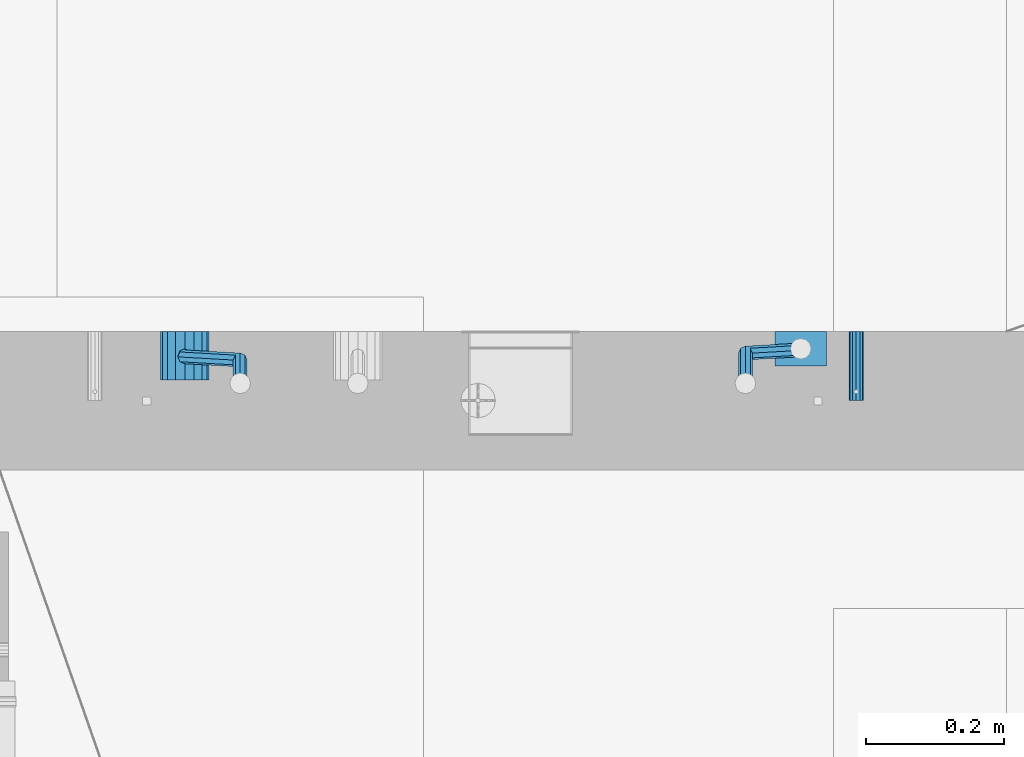
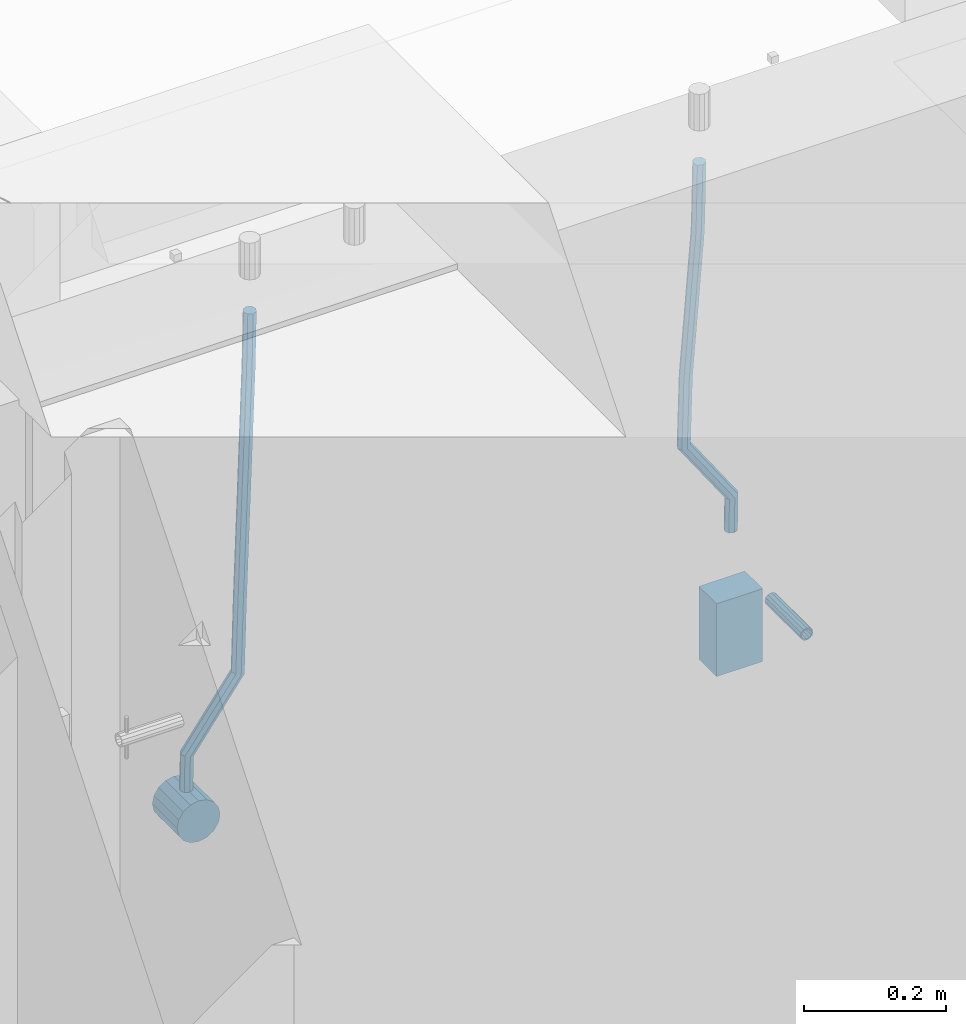
# One storey, part 157 of 334: 5 beams, 2 elements without a shape of their own.
"""IFC2X3 building model written with IfcOpenShell, lengths in millimetres."""

import ifcopenshell
import ifcopenshell.guid

model = None  # the IFC model being written
_history = None  # IfcOwnerHistory: only IFC2X3 demands one
_inside = {}  # id of a spatial element -> (the spatial element, [elements in it])
_under = {}  # id of a project, library or spatial element -> (it, [spatial elements below it])
_declared = {}  # id of a project -> (the project, [libraries it declares])
_typed = {}  # id of a type object -> (the type object, [elements of that type])
_made_of = {}  # id of a material, layer set ... -> (it, [elements and type objects made of it])


def new_model(schema):
    """Start an empty IFC model of exactly this schema.

    Asked for "IFC4X3", IfcOpenShell would pick the latest addendum, in which some entities
    have other attributes; the version numbers below select the first issue.
    IFC2X3 requires an IfcOwnerHistory on every rooted entity: one is made here for all.
    """
    global model, _history
    if schema == "IFC4X3":
        model = ifcopenshell.file(schema_version=(4, 3, 0, 0))
    else:
        model = ifcopenshell.file(schema=schema)
    _inside.clear()
    _under.clear()
    _declared.clear()
    _typed.clear()
    _made_of.clear()
    _history = None
    if model.schema == "IFC2X3":
        org = make("IfcOrganization", Name="unknown")
        user = make(
            "IfcPersonAndOrganization",
            ThePerson=make("IfcPerson", FamilyName="unknown"),
            TheOrganization=org,
        )
        app = make(
            "IfcApplication",
            ApplicationDeveloper=org,
            Version="unknown",
            ApplicationFullName="unknown",
            ApplicationIdentifier="unknown",
        )
        _history = make(
            "IfcOwnerHistory",
            OwningUser=user,
            OwningApplication=app,
            ChangeAction="ADDED",
            CreationDate=0,
        )
    return model


def make(cls, **values):
    """One entity of the class cls with the attributes given. An attribute that is None is left unset."""
    return model.create_entity(
        cls, **{name: value for name, value in values.items() if value is not None}
    )


def rooted(cls, **values):
    """An entity with a GlobalId (a new one), such as an element, a storey or a relation."""
    return make(cls, GlobalId=ifcopenshell.guid.new(), OwnerHistory=_history, **values)


def si_unit(unit_type, name, prefix=None):
    """IfcSIUnit, for example si_unit("LENGTHUNIT", "METRE", prefix="MILLI")."""
    return make("IfcSIUnit", UnitType=unit_type, Prefix=prefix, Name=name)


def assignment(units):
    """IfcUnitAssignment: the units of a project."""
    return None if units is None else make("IfcUnitAssignment", Units=units)


def point(xyz):
    """IfcCartesianPoint."""
    return None if xyz is None else make("IfcCartesianPoint", Coordinates=xyz)


def direction(xyz):
    """IfcDirection."""
    return None if xyz is None else make("IfcDirection", DirectionRatios=xyz)


def frame(location, z_axis=None, x_axis=None):
    """IfcAxis2Placement3D, a coordinate frame: its origin and axes. An axis left out is left unset."""
    return make(
        "IfcAxis2Placement3D",
        Location=point(location),
        Axis=direction(z_axis),
        RefDirection=direction(x_axis),
    )


def origin_with_axes():
    """The frame at (0, 0, 0) with the z axis (0, 0, 1) and the x axis (1, 0, 0) written out."""
    return frame((0.0, 0.0, 0.0), z_axis=(0.0, 0.0, 1.0), x_axis=(1.0, 0.0, 0.0))


def place(relative_to, where):
    """IfcLocalPlacement: puts the frame where relative to a parent placement (None: the world)."""
    return make(
        "IfcLocalPlacement", PlacementRelTo=relative_to, RelativePlacement=where
    )


def context(
    kind, dimensions, precision=None, world=None, true_north=None, identifier=None
):
    """IfcGeometricRepresentationContext, for example the 3D "Model" context."""
    return make(
        "IfcGeometricRepresentationContext",
        ContextIdentifier=identifier,
        ContextType=kind,
        CoordinateSpaceDimension=dimensions,
        Precision=precision,
        WorldCoordinateSystem=world,
        TrueNorth=true_north,
    )


def subcontext(parent, identifier, kind, view, scale=None):
    """IfcGeometricRepresentationSubContext, for example "Body" below "Model"."""
    return make(
        "IfcGeometricRepresentationSubContext",
        ContextIdentifier=identifier,
        ContextType=kind,
        ParentContext=parent,
        TargetScale=scale,
        TargetView=view,
    )


def project(units=None, contexts=None):
    """IfcProject with its units and contexts."""
    return rooted(
        "IfcProject",
        Name="project",
        RepresentationContexts=contexts,
        UnitsInContext=assignment(units),
    )


def spatial(cls, under=None, at=None, **own):
    """A site, building, storey or space (cls), placed at a placement, below another one or the project."""
    s = rooted(cls, ObjectPlacement=at, **own)
    if under is not None:
        _under.setdefault(under.id(), (under, []))[1].append(s)
    return s


def faces_of(points, faces, orient=None, outer=None):
    """IfcFace entities. A face is a list of loops; a loop is a list of indices into points, from 0.

    orient and outer hold one flag for each loop. By default every Orientation is true, the
    first loop of a face is its IfcFaceOuterBound and the others are IfcFaceBound.
    """
    made = []
    for i, loops in enumerate(faces):
        bounds = []
        for j, loop in enumerate(loops):
            is_outer = j == 0 if outer is None else outer[i][j]
            bounds.append(
                make(
                    "IfcFaceOuterBound" if is_outer else "IfcFaceBound",
                    Bound=make("IfcPolyLoop", Polygon=[points[k] for k in loop]),
                    Orientation=True if orient is None else orient[i][j],
                )
            )
        made.append(make("IfcFace", Bounds=bounds))
    return made


def faceted_brep(points, faces, orient=None, outer=None, voids=None):
    """IfcFacetedBrep: a solid bounded by flat faces; with voids (closed shells), ...WithVoids."""
    shared = [point(p) for p in points]
    hull = make("IfcClosedShell", CfsFaces=faces_of(shared, faces, orient, outer))
    if voids is None:
        return make("IfcFacetedBrep", Outer=hull)
    return make(
        "IfcFacetedBrepWithVoids",
        Outer=hull,
        Voids=[
            make(cls, CfsFaces=faces_of(shared, fs, o, b)) for cls, fs, o, b in voids
        ],
    )


def shape(context_of_items, identifier, shape_type, items):
    """IfcShapeRepresentation: the items that make up one representation, for example the "Body"."""
    return make(
        "IfcShapeRepresentation",
        ContextOfItems=context_of_items,
        RepresentationIdentifier=identifier,
        RepresentationType=shape_type,
        Items=items,
    )


def material(Name=None, Category=None):
    """IfcMaterial."""
    return make("IfcMaterial", Name=Name, Category=Category)


def made_of(thing, what):
    """Note that an element or type object is made of a material, layer set ...; save() writes the relation."""
    if what is not None:
        _made_of.setdefault(what.id(), (what, []))[1].append(thing)
    return thing


def type_object(cls, material=None, **own):
    """A type object (cls), such as IfcWallType, which elements share."""
    return made_of(rooted(cls, **own), material)


def element(
    cls,
    number,
    at=None,
    inside=None,
    cuts=None,
    type_object=None,
    material=None,
    context=None,
    identifier="Body",
    shape_type=None,
    held_by="IfcProductDefinitionShape",
    body=None,
    shapes=None,
    **own,
):
    """One element of the class cls, such as IfcWall. Its Tag is "e" and its number.

    at: its placement. inside: the storey or other place that contains it. cuts: it is an
    opening in that element (IfcRelVoidsElement). A single representation is given by context,
    identifier, shape_type and body (its items); several are given by shapes. held_by: the class
    of the entity that holds the representations. save() writes the other relations.
    """
    e = rooted(cls, Tag="e%d" % number, ObjectPlacement=at, **own)
    if body is not None:
        shapes = [shape(context, identifier, shape_type, body)]
    if shapes is not None:
        e.Representation = make(held_by, Representations=shapes)
    if inside is not None:
        _inside.setdefault(inside.id(), (inside, []))[1].append(e)
    if cuts is not None:
        rooted(
            "IfcRelVoidsElement", RelatingBuildingElement=cuts, RelatedOpeningElement=e
        )
    if type_object is not None:
        _typed.setdefault(type_object.id(), (type_object, []))[1].append(e)
    return made_of(e, material)


def aggregate(whole, parts):
    """IfcRelAggregates: a whole, such as a stair, and the parts it consists of."""
    return rooted("IfcRelAggregates", RelatingObject=whole, RelatedObjects=parts)


def save(model, path):
    """Write the relations noted so far, then the file.

    IfcRelAggregates (storeys below a building ...), IfcRelContainedInSpatialStructure (elements
    in a storey), IfcRelDefinesByType, IfcRelAssociatesMaterial and IfcRelDeclares: one each for
    every whole, place, type object, material and project.
    """
    for whole, parts in _under.values():
        aggregate(whole, parts)
    for where, things in _inside.values():
        rooted(
            "IfcRelContainedInSpatialStructure",
            RelatedElements=things,
            RelatingStructure=where,
        )
    for kind, things in _typed.values():
        rooted("IfcRelDefinesByType", RelatedObjects=things, RelatingType=kind)
    for what, things in _made_of.values():
        rooted("IfcRelAssociatesMaterial", RelatedObjects=things, RelatingMaterial=what)
    for by, libraries in _declared.values():
        rooted("IfcRelDeclares", RelatingContext=by, RelatedDefinitions=libraries)
    model.write(path)


model = new_model("IFC2X3")

# Units and contexts
model_context = context("Model", 3, precision=1e-05, world=origin_with_axes())
body_context = subcontext(model_context, "Body", "Model", "MODEL_VIEW")
ifc_project = project(units=[si_unit("LENGTHUNIT", "METRE", prefix="MILLI"), si_unit("AREAUNIT", "SQUARE_METRE"), si_unit("VOLUMEUNIT", "CUBIC_METRE"), si_unit("MASSUNIT", "GRAM", prefix="KILO"), si_unit("TIMEUNIT", "SECOND"), si_unit("PLANEANGLEUNIT", "RADIAN"), si_unit("SOLIDANGLEUNIT", "STERADIAN"), si_unit("THERMODYNAMICTEMPERATUREUNIT", "DEGREE_CELSIUS"), si_unit("LUMINOUSINTENSITYUNIT", "LUMEN")], contexts=[model_context])

# Site, building, storey
site_placement = place(None, origin_with_axes())
site = spatial("IfcSite", under=ifc_project, at=site_placement, CompositionType="ELEMENT")
building_placement = place(site_placement, origin_with_axes())
building = spatial("IfcBuilding", under=site, at=building_placement, CompositionType="ELEMENT")
storey_placement = place(building_placement, origin_with_axes())
storey = spatial("IfcBuildingStorey", under=building, at=storey_placement, Name="3", CompositionType="ELEMENT", Elevation=0.0)

# Assemblies, beams
assembly_1_placement = place(storey_placement, origin_with_axes())
assembly_1 = element("IfcElementAssembly", 1, at=assembly_1_placement, inside=storey, AssemblyPlace="NOTDEFINED", PredefinedType="REINFORCEMENT_UNIT")
assembly_2_placement = place(assembly_1_placement, origin_with_axes())
assembly_2 = element("IfcElementAssembly", 2, at=assembly_2_placement, Name="Steel Assembly", AssemblyPlace="NOTDEFINED", PredefinedType="RIGID_FRAME")
ifc_material_1 = material(Name="STEEL/Steel_Undefined")
beam_type_1 = type_object("IfcBeamType", PredefinedType="NOTDEFINED")
beam_1_placement = place(assembly_2_placement, frame((27934.9999668009, 17080.0, 89555.0), z_axis=(1.0, 0.0, 0.0), x_axis=(0.0, -1.0, 0.0)))
beam_1 = element("IfcBeam", 3, at=beam_1_placement, type_object=beam_type_1, material=ifc_material_1, Name="M16", context=body_context, shape_type="Brep", body=[
    faceted_brep([(0.0, -8.49999999999272, -1.45519152283669e-11), (0.0, -7.36121593215648, 4.24999999998545), (100.000000000262, -7.36121593215648, 4.24999999998545), (100.000000000262, -8.49999999999272, -1.45519152283669e-11), (0.0, -4.24999999998545, 7.36121593216376), (100.000000000262, -4.24999999998545, 7.36121593216376), (0.0, 1.45519152283669e-11, 8.49999999998545), (100.000000000262, 1.45519152283669e-11, 8.49999999998545), (0.0, 4.25000000001455, 7.36121593216376), (100.000000000262, 4.25000000001455, 7.36121593216376), (0.0, 7.36121593217104, 4.24999999998545), (100.000000000262, 7.36121593217104, 4.24999999998545), (0.0, 8.50000000000728, 0.0), (100.000000000262, 8.50000000000728, 0.0), (0.0, 7.36121593217104, -4.25000000001455), (100.000000000262, 7.36121593217104, -4.25000000001455), (0.0, 4.25000000000728, -7.36121593219286), (100.000000000262, 4.25000000000728, -7.36121593219286), (0.0, 7.27595761418343e-12, -8.5), (100.000000000262, 7.27595761418343e-12, -8.5), (0.0, -4.24999999999272, -7.36121593217831), (100.000000000262, -4.24999999999272, -7.36121593217831), (0.0, -7.36121593215648, -4.25), (100.000000000262, -7.36121593215648, -4.25), (0.0, -10.4999999999927, -1.45519152283669e-11), (0.0, -9.09326673972828, -5.25000000001455), (100.000000000262, -9.09326673972828, -5.25000000001455), (100.000000000262, -10.4999999999927, -1.45519152283669e-11), (0.0, -5.24999999998545, -9.09326673974283), (100.000000000262, -5.24999999998545, -9.09326673974283), (0.0, 7.27595761418343e-12, -10.5), (100.000000000262, 7.27595761418343e-12, -10.5), (0.0, 5.25000000001455, -9.09326673975738), (100.000000000262, 5.25000000001455, -9.09326673975738), (0.0, 9.09326673975011, -5.25000000001455), (100.000000000262, 9.09326673975011, -5.25000000001455), (0.0, 10.5000000000073, -1.45519152283669e-11), (100.000000000262, 10.5000000000073, -1.45519152283669e-11), (0.0, 9.09326673975011, 5.25), (100.000000000262, 9.09326673975011, 5.25), (0.0, 5.25000000000728, 9.09326673972828), (100.000000000262, 5.25000000000728, 9.09326673972828), (0.0, 1.45519152283669e-11, 10.4999999999854), (100.000000000262, 1.45519152283669e-11, 10.4999999999854), (0.0, -5.24999999999272, 9.09326673972828), (100.000000000262, -5.24999999999272, 9.09326673972828), (0.0, -9.09326673972828, 5.24999999998545), (100.000000000262, -9.09326673972828, 5.24999999998545)], [[[0, 1, 2, 3]], [[1, 4, 5, 2]], [[4, 6, 7, 5]], [[6, 8, 9, 7]], [[8, 10, 11, 9]], [[10, 12, 13, 11]], [[12, 14, 15, 13]], [[14, 16, 17, 15]], [[16, 18, 19, 17]], [[18, 20, 21, 19]], [[20, 22, 23, 21]], [[22, 0, 3, 23]], [[24, 25, 26, 27]], [[25, 28, 29, 26]], [[28, 30, 31, 29]], [[30, 32, 33, 31]], [[32, 34, 35, 33]], [[34, 36, 37, 35]], [[36, 38, 39, 37]], [[38, 40, 41, 39]], [[40, 42, 43, 41]], [[42, 44, 45, 43]], [[44, 46, 47, 45]], [[46, 24, 27, 47]], [[29, 31, 33, 35, 37, 39, 41, 43, 45, 47, 27, 26], [5, 7, 9, 11, 13, 15, 17, 19, 21, 23, 3, 2]], [[46, 44, 42, 40, 38, 36, 34, 32, 30, 28, 25, 24], [22, 20, 18, 16, 14, 12, 10, 8, 6, 4, 1, 0]]]),
])
aggregate(assembly_2, [beam_1])
ifc_material_2 = material()
beam_type_2 = type_object("IfcBeamType", Name="D20", PredefinedType="NOTDEFINED")
beam_2_placement = place(assembly_1_placement, frame((27854.9999105249, 17055.0000022791, 89717.5), z_axis=(0.00020576299992186, -0.999642804629538, -0.0267249099901004), x_axis=(-4.30000201928125e-08, -0.0267249099948059, 0.999642825806181)))
beam_2 = element("IfcBeam", 4, at=beam_2_placement, type_object=beam_type_2, material=ifc_material_2, Name="JM20", ObjectType="D20", context=body_context, shape_type="Brep", body=[
    faceted_brep([(0.0, -10.0, 0.0), (-4.19531716033816e-08, -7.07106781186667, -7.07106781187031), (57.3778003524785, -7.07106779628884, -7.0710678060168), (57.3778003565822, -9.99999998442945, 5.84986992180347e-09), (0.0, 0.0, -10.0), (57.3778003491898, 1.55741872731596e-08, -9.99999999415013), (4.196772351861e-08, 7.07106781186303, -7.07106781186667), (57.3778003486368, 7.07106782744086, -7.0710678060168), (0.0, 10.0, 0.0), (57.3778003511543, 10.0000000155705, 5.84986992180347e-09), (4.196772351861e-08, 7.07106781185939, 7.07106781185939), (57.3778003552725, 7.07106782744086, 7.0710678177129), (0.0, 0.0, 10.0), (57.3778003585467, 1.55741872731596e-08, 10.0000000058535), (-4.19531716033816e-08, -7.07106781187031, 7.07106781185939), (57.3778003591142, -7.07106779628884, 7.0710678177129), (63.2348501311644, -7.07106779493188, -7.07106780540926), (64.1057957623998, -9.99999998283238, 6.54472387395799e-09), (61.04994790192, 1.63490767590702e-08, -9.99999999377178), (58.8309751681372, 7.07106782761548, -7.07106780586037), (57.8777760627127, 10.0000000155014, 5.90807758271694e-09), (58.7487216939626, 7.07106782759729, 7.07106781786206), (60.9336239231925, 1.63163349498063e-08, 10.0000000062173), (63.1525966569752, -7.07106779495371, 7.07106781830953), (68.0560815638019, -3.74583294561307, -7.00896065082998), (69.6439432500047, -6.18030344188082, 0.0713424813729944), (64.0726841869619, 2.08480100043016, -9.96106107280502), (60.0271712784888, 7.89609210789058, -7.05565839484916), (58.2893494334276, 10.283864860914, 0.00530189843993867), (59.8772111196158, 7.84939436464629, 7.08560503063927), (63.8606084964704, 2.01876041860305, 10.037705452618), (67.9061214049289, -3.79253068885737, 7.13230277466573), (178.098456601496, 72.1511127806843, -5.59139360533663), (179.686318287684, 69.716642284413, 1.48890952685906), (174.115059224641, 77.9817467267239, -8.54349402731532), (170.069546316168, 83.7930378341844, -5.63809134935946), (168.331724471092, 86.1808105872078, 1.42286894392964), (169.91958615731, 83.7463400909437, 8.50317207612898), (173.90298353415, 77.9157061448968, 11.455272498104), (177.948496442623, 72.1044150374437, 8.5498698201518), (179.289255982527, 72.9724149014583, -5.57605371504542), (180.097891658399, 70.0005071298292, 1.4942114193982), (177.129995245661, 80.0611678177193, -8.50465558942597), (174.884975102759, 87.1142705605816, -5.5760589445199), (173.869297905752, 90.00011120009, 1.49420402380565), (174.67793358161, 87.0282034284573, 8.5644691582529), (176.837194318476, 79.9394505121963, 11.4930710326298), (179.082214461378, 72.8863477693376, 8.56447438772739), (180.735622590379, 72.972420835973, -5.54778204405011), (180.597796167538, 70.0005091809617, 1.50398289485383), (180.791991426609, 80.0611828430738, -8.4330757073476), (180.733882576489, 87.1142945589418, -5.46173219850607), (180.595335416292, 90.0001387973534, 1.62567575346111), (180.457508993451, 87.0282271423457, 8.67744069236505), (180.401140157206, 79.939465135245, 11.5627343556625), (180.459249007356, 72.8863534193733, 8.59139084682101), (299.223827734662, 72.9729069989553, -3.23173054285144), (299.086001311836, 70.0009953439476, 3.82003439605251), (299.280196570893, 80.0616690060597, -6.11702420615256), (299.222087720773, 87.1147807219277, -3.14568069731467), (299.083540560576, 90.0006249603393, 3.94172725465251), (298.945714137735, 87.0287133053316, 10.9934921935564), (298.889345301504, 79.9399512982272, 13.8787858568576), (298.947454151639, 72.8868395823556, 10.9074423480197), (300.386274806908, 72.9729117685347, -3.20900855728542), (299.975441269635, 70.0009989933678, 3.8374199978316), (300.554299891708, 80.0616742337661, -6.09211971118202), (300.381089708186, 87.1147854773699, -3.12302605173682), (299.968108432717, 90.0006285897653, 3.95901762330686), (299.557274895458, 87.0287158145948, 11.0054461784239), (299.389249810658, 79.9399533493597, 13.8885573323169), (299.562459994166, 72.8868421057559, 10.9194636728716), (301.54348499664, 72.972935138263, -3.09647384826167), (300.860874255726, 70.0010168745794, 3.92352530897551), (301.822663312996, 80.0616998482183, -5.96877573286474), (301.534870333402, 87.1148087778347, -3.01082485606094), (300.848691282124, 90.0006463730351, 4.04465127535514), (300.166080541225, 87.0287281093551, 11.0646504325923), (299.886902224855, 79.9399633993926, 13.9369523171918), (300.174695204449, 72.8868544697798, 10.9790014403879), (567.277632096637, 72.9783016087349, 22.7452575737989), (566.595021355723, 70.0063833450513, 29.7652567310361), (567.556810412992, 80.0670663186975, 19.8729556891958), (567.269017433413, 87.1201752483139, 22.8309065659996), (566.582838382135, 90.0060128435071, 29.886382697412), (565.900227641221, 87.0340945798234, 36.9063818546456), (565.621049324851, 79.9453298698681, 39.7786837392523), (565.90884230446, 72.8922209402554, 36.8207328624449), (567.849310941645, 72.9783131537188, 22.8008513743443), (567.441064932689, 70.0064004308078, 29.8475315576834), (568.054462827218, 80.0670763687303, 19.9213506740707), (567.93634539716, 87.1201887249226, 22.8958019142228), (567.564150240039, 90.0060326609891, 29.9818118989315), (567.155904231084, 87.0341199380709, 37.0284920822669), (566.950752345525, 79.9453567230667, 39.9079927825405), (567.068869775569, 72.8922443668707, 36.9335415423957), (568.423586898687, 72.9708243880268, 22.8084944200891), (568.290952048657, 69.9953175961527, 29.8588427157192), (568.554376054599, 80.0605573198627, 19.9280040253361), (568.606705002705, 87.1114469937784, 22.9047237384184), (568.549920154881, 89.9931778656028, 29.9949315228005), (568.417285304851, 87.0176710737251, 37.0452798184269), (568.286496148939, 79.9279381418964, 39.9257702131799), (568.234167200833, 72.8770484679771, 36.9490505000977), (589.912124239258, 72.6906061074042, 23.0944856267633), (589.779489389242, 69.7150993155265, 30.1448339223862), (590.042913395198, 79.7803390392328, 20.2139952320067), (590.095242343275, 86.8312287131521, 23.190714945089), (590.038457495451, 89.7129595849765, 30.2809227294711), (589.905822645451, 86.7374527930988, 37.3312710250975), (589.775033489525, 79.6477198612702, 40.2117614198505), (589.722704541418, 72.5968301873472, 37.2350417067682), (590.547165551296, 72.6823249395493, 23.1029373993588), (590.439554471668, 69.7064918286778, 30.1536187366546), (590.620682129796, 79.7728047264573, 20.2216847631717), (590.617039192599, 86.8244242939545, 23.197659545749), (590.538370722847, 89.7064405361089, 30.2875760807365), (590.430759643248, 86.7306074252338, 37.3382574180287), (590.357243064718, 79.6401276383258, 40.2195100542194), (590.36088600193, 72.5885080708285, 37.243535271642), (591.182260594243, 72.6841934809891, 23.1112002334121), (591.099675200006, 69.7084600799535, 30.1622167658497), (591.198500084778, 79.7744922147613, 20.2291794306657), (591.138880798317, 86.8259554442993, 23.2044030568104), (591.038326904265, 89.7079316443269, 30.2940254627501), (590.955741510043, 86.7321982432914, 37.3450419951805), (590.939502019522, 79.6418995095191, 40.2270627979342), (590.999121305984, 72.5904362799774, 37.2518391717822), (691.203058405095, 72.9824563748625, 24.4085746238379), (691.120473010888, 70.0067229738306, 31.4595911562756), (691.219297895645, 80.0727551086347, 21.5265538210951), (691.159678609169, 87.1242183381728, 24.5017774472362), (691.059124715146, 90.0061945381967, 31.591399853176), (690.976539320895, 87.0304611371721, 38.6424163856136), (690.960299830374, 79.9401624033926, 41.5244371883564), (691.019919116836, 72.8886991738545, 38.5492135622153)], [[[0, 1, 2, 3]], [[1, 4, 5, 2]], [[4, 6, 7, 5]], [[6, 8, 9, 7]], [[8, 10, 11, 9]], [[10, 12, 13, 11]], [[12, 14, 15, 13]], [[14, 0, 3, 15]], [[14, 12, 10, 8, 6, 4, 1, 0]], [[3, 2, 16, 17]], [[2, 5, 18, 16]], [[5, 7, 19, 18]], [[7, 9, 20, 19]], [[9, 11, 21, 20]], [[11, 13, 22, 21]], [[13, 15, 23, 22]], [[15, 3, 17, 23]], [[17, 16, 24, 25]], [[16, 18, 26, 24]], [[18, 19, 27, 26]], [[19, 20, 28, 27]], [[20, 21, 29, 28]], [[21, 22, 30, 29]], [[22, 23, 31, 30]], [[23, 17, 25, 31]], [[25, 24, 32, 33]], [[24, 26, 34, 32]], [[26, 27, 35, 34]], [[27, 28, 36, 35]], [[28, 29, 37, 36]], [[29, 30, 38, 37]], [[30, 31, 39, 38]], [[31, 25, 33, 39]], [[33, 32, 40, 41]], [[32, 34, 42, 40]], [[34, 35, 43, 42]], [[35, 36, 44, 43]], [[36, 37, 45, 44]], [[37, 38, 46, 45]], [[38, 39, 47, 46]], [[39, 33, 41, 47]], [[41, 40, 48, 49]], [[40, 42, 50, 48]], [[42, 43, 51, 50]], [[43, 44, 52, 51]], [[44, 45, 53, 52]], [[45, 46, 54, 53]], [[46, 47, 55, 54]], [[47, 41, 49, 55]], [[49, 48, 56, 57]], [[48, 50, 58, 56]], [[50, 51, 59, 58]], [[51, 52, 60, 59]], [[52, 53, 61, 60]], [[53, 54, 62, 61]], [[54, 55, 63, 62]], [[55, 49, 57, 63]], [[57, 56, 64, 65]], [[56, 58, 66, 64]], [[58, 59, 67, 66]], [[59, 60, 68, 67]], [[60, 61, 69, 68]], [[61, 62, 70, 69]], [[62, 63, 71, 70]], [[63, 57, 65, 71]], [[65, 64, 72, 73]], [[64, 66, 74, 72]], [[66, 67, 75, 74]], [[67, 68, 76, 75]], [[68, 69, 77, 76]], [[69, 70, 78, 77]], [[70, 71, 79, 78]], [[71, 65, 73, 79]], [[73, 72, 80, 81]], [[72, 74, 82, 80]], [[74, 75, 83, 82]], [[75, 76, 84, 83]], [[76, 77, 85, 84]], [[77, 78, 86, 85]], [[78, 79, 87, 86]], [[79, 73, 81, 87]], [[81, 80, 88, 89]], [[80, 82, 90, 88]], [[82, 83, 91, 90]], [[83, 84, 92, 91]], [[84, 85, 93, 92]], [[85, 86, 94, 93]], [[86, 87, 95, 94]], [[87, 81, 89, 95]], [[89, 88, 96, 97]], [[88, 90, 98, 96]], [[90, 91, 99, 98]], [[91, 92, 100, 99]], [[92, 93, 101, 100]], [[93, 94, 102, 101]], [[94, 95, 103, 102]], [[95, 89, 97, 103]], [[97, 96, 104, 105]], [[96, 98, 106, 104]], [[98, 99, 107, 106]], [[99, 100, 108, 107]], [[100, 101, 109, 108]], [[101, 102, 110, 109]], [[102, 103, 111, 110]], [[103, 97, 105, 111]], [[105, 104, 112, 113]], [[104, 106, 114, 112]], [[106, 107, 115, 114]], [[107, 108, 116, 115]], [[108, 109, 117, 116]], [[109, 110, 118, 117]], [[110, 111, 119, 118]], [[111, 105, 113, 119]], [[113, 112, 120, 121]], [[112, 114, 122, 120]], [[114, 115, 123, 122]], [[115, 116, 124, 123]], [[116, 117, 125, 124]], [[117, 118, 126, 125]], [[118, 119, 127, 126]], [[119, 113, 121, 127]], [[121, 120, 128, 129]], [[120, 122, 130, 128]], [[122, 123, 131, 130]], [[123, 124, 132, 131]], [[124, 125, 133, 132]], [[125, 126, 134, 133]], [[126, 127, 135, 134]], [[127, 121, 129, 135]], [[130, 131, 132, 133, 134, 135, 129, 128]]]),
])
beam_3_placement = place(assembly_1_placement, frame((26964.9999105249, 17045.0000022791, 89590.0), z_axis=(0.00020576299992186, -0.999642804629538, -0.0267249099901004), x_axis=(-4.30000201928125e-08, -0.0267249099948059, 0.999642825806181)))
beam_3 = element("IfcBeam", 5, at=beam_3_placement, type_object=beam_type_2, material=ifc_material_2, Name="JM20", ObjectType="D20", context=body_context, shape_type="Brep", body=[
    faceted_brep([(0.0, -10.0, 0.0), (-4.19531716033816e-08, -7.07106781186667, -7.07106781187031), (57.3778003524785, -7.07106779628884, -7.0710678060168), (57.3778003565822, -9.99999998442945, 5.84986992180347e-09), (0.0, 0.0, -10.0), (57.3778003491898, 1.55741872731596e-08, -9.99999999415013), (4.196772351861e-08, 7.07106781186303, -7.07106781186667), (57.3778003486368, 7.07106782744086, -7.0710678060168), (0.0, 10.0, 0.0), (57.3778003511543, 10.0000000155705, 5.84986992180347e-09), (4.196772351861e-08, 7.07106781185939, 7.07106781185939), (57.3778003552725, 7.07106782744086, 7.0710678177129), (0.0, 0.0, 10.0), (57.3778003585467, 1.55741872731596e-08, 10.0000000058535), (-4.19531716033816e-08, -7.07106781187031, 7.07106781185939), (57.3778003591142, -7.07106779628884, 7.0710678177129), (58.8318985002552, -7.07106779589958, -7.07106780586764), (57.8778003565822, -9.99999998429485, 5.90443960390985e-09), (61.0512293968495, 1.65709934663028e-08, -9.99999999377542), (63.2357391065598, 7.07106782902702, -7.07106780541653), (64.1057714685594, 10.0000000174005, 6.53744791634381e-09), (63.1516733248864, 7.07106782900519, 7.07106781830589), (60.932342428292, 1.65382516570389e-08, 10.0000000062137), (58.7478327185672, -7.07106779591777, 7.07106781785842), (60.0288346662128, -7.89659605236375, -7.05530913284747), (58.2893737320846, -10.2838626168559, 0.0054187161331356), (64.075000582452, -2.08549846343158, -9.96018949865174), (68.0576823626325, 3.74536799461202, -7.00758286006021), (69.6438790345856, 6.18036083103652, 0.0729138583883469), (67.9044181004574, 3.79309426654072, 7.13364170736895), (63.8582521842327, -2.01800332238781, 10.0385220731696), (59.8755704040377, -7.84886978043505, 7.08591543458169), (170.071205978675, -83.7929466763271, -5.60650860604073), (168.331745044532, -86.1802132408156, 1.45421924293987), (174.117371894885, -77.9818490873949, -8.51138897184137), (178.100053675094, -72.150982629355, -5.55878233325711), (179.686250347047, -69.7159897929341, 1.52171438519144), (177.946789412905, -72.1032563574299, 8.58244223417205), (173.90062349668, -77.9143539463585, 11.4873225999763), (169.9179417165, -83.7452204043984, 8.53471596138843), (174.885917629814, -87.1136588644658, -5.54311887085714), (173.869352081325, -89.9995072115853, 1.52712650490139), (177.131269974328, -80.0605380746747, -8.47170846447989), (179.290112163741, -72.9717673438317, -5.54311421065358), (180.09782372255, -69.9998524254988, 1.52713309542378), (179.081258174047, -72.8857007726183, 8.59737847118231), (176.835905829546, -79.9388215623985, 11.5259680648051), (174.677063640134, -87.0275922932524, 8.59737381097511), (180.733953989722, -87.1136352324538, -5.42880915215937), (180.595430327434, -89.999480031398, 1.65859903088131), (180.792005409938, -80.0605232815869, -8.40015322574254), (180.735578853404, -72.9717615026784, -5.51486013004978), (180.597728231689, -69.9998504053765, 1.53690457089033), (180.459204569401, -72.885695204317, 8.62431275393101), (180.401153149185, -79.9388071551803, 11.5956568275142), (180.457579705719, -87.0275689340961, 8.71036373181778), (299.547258407722, -87.113155105988, -3.10640303667606), (299.408734745448, -89.9989999049212, 3.98100514636099), (299.605309827937, -80.0600431551138, -6.07774711026286), (299.548883271418, -72.9712813762017, -3.1924540145701), (299.411032649703, -69.9993702789034, 3.85931068637365), (299.2725089874, -72.8852150778403, 10.9467188694071), (299.214457567214, -79.9383270287144, 13.9180629429939), (299.270884123718, -87.0270888076229, 11.0327698472975), (300.152711613046, -87.1131526593381, -3.09456843420048), (299.970255028908, -89.998997635812, 3.99198100589638), (300.229173865737, -80.0600406340709, -6.06555263706105), (300.154851236337, -72.9712789274818, -3.18060935024914), (299.973280913182, -69.999368006851, 3.87030077550298), (299.790824329029, -72.8852129833249, 10.9568502155962), (299.714362076353, -79.9383250085921, 13.9278344184604), (299.788684705738, -87.0270867151812, 11.0428911316449), (300.757971557832, -87.1131486122868, -3.07522829750815), (300.53159607522, -89.9989938824292, 4.0099177827542), (300.852838766252, -80.0600364639577, -6.04562439873916), (300.760625776413, -72.9712748769889, -3.16125277046012), (300.535349707119, -69.9993642486006, 3.88826080639774), (300.308974224507, -72.8852095187322, 10.9734068866528), (300.214107016072, -79.9383216670649, 13.9438029878838), (300.306320005926, -87.0270832540336, 11.0594313596121), (694.302737300924, -87.1105171895797, 9.49988035006754), (694.076361818312, -89.9963624597149, 16.585026430319), (694.397604509359, -80.0574050412542, 6.52948424883652), (694.305391519505, -72.9686434542782, 9.41385587710465), (694.080115450226, -69.9967328258899, 16.4633694539662), (693.853739967599, -72.8825780960215, 23.5485155342212), (693.758872759179, -79.9356902443542, 26.5189116354522), (693.851085749033, -87.0244518313229, 23.6345400071805), (694.802482240659, -87.1105138480525, 9.51584891948733), (694.623303945409, -89.9963588026076, 16.6025031121862), (694.915659771606, -80.0574015772909, 6.54603789603061), (694.896538675588, -72.968639501596, 9.4327450616729), (694.756319831315, -69.996728304468, 16.4849765093786), (694.57714153605, -72.8825732590267, 23.5716307020812), (694.463964005088, -79.9356855297883, 26.5414417255342), (694.483085101121, -87.0244476054831, 23.6547345598919), (695.302395468068, -87.1170328969201, 9.52250227075638), (695.170430253667, -90.0034935270887, 16.6097848229292), (695.433889487511, -80.064159479778, 6.55293502166751), (695.487884898772, -72.9763508697215, 9.44061529579994), (695.432751922272, -70.0055492230131, 16.4939791523611), (695.30078670787, -72.892009853178, 23.581261704534), (695.169292688428, -79.9448832703201, 26.5508289536265), (695.115297277152, -87.0326918803803, 23.6631486794868), (717.096960509152, -87.4012418891907, 9.81256640384163), (716.96499529478, -90.2877025193593, 16.8998489560108), (717.228454528595, -80.3483684720522, 6.84299915475276), (717.28244993987, -73.2605598619884, 9.73067942887792), (717.227316963355, -70.2897582152873, 16.7840432854464), (717.095351748983, -73.1762188454522, 23.8713258376192), (716.963857729526, -80.2290922625871, 26.8408930867081), (716.909862318265, -87.3169008726472, 23.9532128125757), (717.732752035779, -87.4095328401163, 9.82102816105544), (717.62510360773, -90.2963105699491, 16.9086343456293), (717.807253658262, -80.3559162215497, 6.85070239946072), (717.804966435171, -73.2673736656325, 9.73763360732119), (717.727230190765, -70.2962772641549, 16.7906966367118), (717.61958176273, -73.1830549939841, 23.8783028212929), (717.545080140233, -80.2366716125471, 26.8486285828913), (717.547367363324, -87.3252141684679, 23.9616973750308), (718.368597467226, -87.4076503896285, 9.82928955306488), (718.285267778789, -90.2943418380746, 16.9172167822726), (718.386102043136, -80.3542095057164, 6.85821078440495), (718.327527563335, -73.2658291947409, 9.74439812407945), (718.227186163713, -70.2947865076021, 16.7971621720717), (718.143856475261, -73.1814779560518, 23.885089401283), (718.126351899366, -80.2349188399603, 26.8561681699393), (718.184926379137, -87.3232991509467, 23.9699808302648), (818.389373660975, -87.1093875602128, 11.1266636631008), (818.306043972552, -89.9960790086589, 18.2145908923085), (818.4068782369, -80.0559466763007, 8.1555848944372), (818.348303757099, -72.9675663653215, 11.0417722341153), (818.247962357447, -69.9965236781827, 18.0945362821076), (818.16463266901, -72.8832151266324, 25.1824635113153), (818.1471280931, -79.9366560105409, 28.1535422799789), (818.205702572901, -87.0250363215273, 25.2673549403007)], [[[0, 1, 2, 3]], [[1, 4, 5, 2]], [[4, 6, 7, 5]], [[6, 8, 9, 7]], [[8, 10, 11, 9]], [[10, 12, 13, 11]], [[12, 14, 15, 13]], [[14, 0, 3, 15]], [[14, 12, 10, 8, 6, 4, 1, 0]], [[3, 2, 16, 17]], [[2, 5, 18, 16]], [[5, 7, 19, 18]], [[7, 9, 20, 19]], [[9, 11, 21, 20]], [[11, 13, 22, 21]], [[13, 15, 23, 22]], [[15, 3, 17, 23]], [[17, 16, 24, 25]], [[16, 18, 26, 24]], [[18, 19, 27, 26]], [[19, 20, 28, 27]], [[20, 21, 29, 28]], [[21, 22, 30, 29]], [[22, 23, 31, 30]], [[23, 17, 25, 31]], [[25, 24, 32, 33]], [[24, 26, 34, 32]], [[26, 27, 35, 34]], [[27, 28, 36, 35]], [[28, 29, 37, 36]], [[29, 30, 38, 37]], [[30, 31, 39, 38]], [[31, 25, 33, 39]], [[33, 32, 40, 41]], [[32, 34, 42, 40]], [[34, 35, 43, 42]], [[35, 36, 44, 43]], [[36, 37, 45, 44]], [[37, 38, 46, 45]], [[38, 39, 47, 46]], [[39, 33, 41, 47]], [[41, 40, 48, 49]], [[40, 42, 50, 48]], [[42, 43, 51, 50]], [[43, 44, 52, 51]], [[44, 45, 53, 52]], [[45, 46, 54, 53]], [[46, 47, 55, 54]], [[47, 41, 49, 55]], [[49, 48, 56, 57]], [[48, 50, 58, 56]], [[50, 51, 59, 58]], [[51, 52, 60, 59]], [[52, 53, 61, 60]], [[53, 54, 62, 61]], [[54, 55, 63, 62]], [[55, 49, 57, 63]], [[57, 56, 64, 65]], [[56, 58, 66, 64]], [[58, 59, 67, 66]], [[59, 60, 68, 67]], [[60, 61, 69, 68]], [[61, 62, 70, 69]], [[62, 63, 71, 70]], [[63, 57, 65, 71]], [[65, 64, 72, 73]], [[64, 66, 74, 72]], [[66, 67, 75, 74]], [[67, 68, 76, 75]], [[68, 69, 77, 76]], [[69, 70, 78, 77]], [[70, 71, 79, 78]], [[71, 65, 73, 79]], [[73, 72, 80, 81]], [[72, 74, 82, 80]], [[74, 75, 83, 82]], [[75, 76, 84, 83]], [[76, 77, 85, 84]], [[77, 78, 86, 85]], [[78, 79, 87, 86]], [[79, 73, 81, 87]], [[81, 80, 88, 89]], [[80, 82, 90, 88]], [[82, 83, 91, 90]], [[83, 84, 92, 91]], [[84, 85, 93, 92]], [[85, 86, 94, 93]], [[86, 87, 95, 94]], [[87, 81, 89, 95]], [[89, 88, 96, 97]], [[88, 90, 98, 96]], [[90, 91, 99, 98]], [[91, 92, 100, 99]], [[92, 93, 101, 100]], [[93, 94, 102, 101]], [[94, 95, 103, 102]], [[95, 89, 97, 103]], [[97, 96, 104, 105]], [[96, 98, 106, 104]], [[98, 99, 107, 106]], [[99, 100, 108, 107]], [[100, 101, 109, 108]], [[101, 102, 110, 109]], [[102, 103, 111, 110]], [[103, 97, 105, 111]], [[105, 104, 112, 113]], [[104, 106, 114, 112]], [[106, 107, 115, 114]], [[107, 108, 116, 115]], [[108, 109, 117, 116]], [[109, 110, 118, 117]], [[110, 111, 119, 118]], [[111, 105, 113, 119]], [[113, 112, 120, 121]], [[112, 114, 122, 120]], [[114, 115, 123, 122]], [[115, 116, 124, 123]], [[116, 117, 125, 124]], [[117, 118, 126, 125]], [[118, 119, 127, 126]], [[119, 113, 121, 127]], [[121, 120, 128, 129]], [[120, 122, 130, 128]], [[122, 123, 131, 130]], [[123, 124, 132, 131]], [[124, 125, 133, 132]], [[125, 126, 134, 133]], [[126, 127, 135, 134]], [[127, 121, 129, 135]], [[130, 131, 132, 133, 134, 135, 129, 128]]]),
])
beam_type_3 = type_object("IfcBeamType", Name="D70", PredefinedType="NOTDEFINED")
beam_4_placement = place(assembly_1_placement, frame((26964.9999105288, 17080.0000022791, 89555.0), z_axis=(0.0, 0.0, 1.0), x_axis=(0.0, -1.0, 0.0)))
beam_4 = element("IfcBeam", 6, at=beam_4_placement, type_object=beam_type_3, material=ifc_material_2, ObjectType="D70", context=body_context, shape_type="Brep", body=[
    faceted_brep([(0.0, -35.0, 0.0), (0.0, -32.3357836378964, -13.3939201327739), (70.0, -32.3357836378964, -13.3939201327739), (70.0, -35.0, 0.0), (0.0, -24.7487373415279, -24.7487373415352), (70.0, -24.7487373415279, -24.7487373415352), (0.0, -13.3939201327776, -32.3357836379), (70.0, -13.3939201327776, -32.3357836379), (0.0, 0.0, -35.0), (70.0, 0.0, -35.0), (0.0, 13.3939201327776, -32.3357836379), (70.0, 13.3939201327776, -32.3357836379), (0.0, 24.7487373415279, -24.7487373415352), (70.0, 24.7487373415279, -24.7487373415352), (0.0, 32.3357836378964, -13.3939201327739), (70.0, 32.3357836378964, -13.3939201327739), (0.0, 35.0, 0.0), (70.0, 35.0, 0.0), (0.0, 32.3357836378964, 13.3939201327739), (70.0, 32.3357836378964, 13.3939201327739), (0.0, 24.7487373415279, 24.7487373415352), (70.0, 24.7487373415279, 24.7487373415352), (0.0, 13.3939201327776, 32.3357836379), (70.0, 13.3939201327776, 32.3357836379), (0.0, 0.0, 35.0), (70.0, 0.0, 35.0), (0.0, -13.3939201327776, 32.3357836379), (70.0, -13.3939201327776, 32.3357836379), (0.0, -24.7487373415279, 24.7487373415352), (70.0, -24.7487373415279, 24.7487373415352), (0.0, -32.3357836378964, 13.3939201327739), (70.0, -32.3357836378964, 13.3939201327739)], [[[0, 1, 2, 3]], [[1, 4, 5, 2]], [[4, 6, 7, 5]], [[6, 8, 9, 7]], [[8, 10, 11, 9]], [[10, 12, 13, 11]], [[12, 14, 15, 13]], [[14, 16, 17, 15]], [[16, 18, 19, 17]], [[18, 20, 21, 19]], [[20, 22, 23, 21]], [[22, 24, 25, 23]], [[24, 26, 27, 25]], [[26, 28, 29, 27]], [[28, 30, 31, 29]], [[30, 0, 3, 31]], [[5, 7, 9, 11, 13, 15, 17, 19, 21, 23, 25, 27, 29, 31, 3, 2]], [[30, 28, 26, 24, 22, 20, 18, 16, 14, 12, 10, 8, 6, 4, 1, 0]]]),
])
beam_type_4 = type_object("IfcBeamType", PredefinedType="NOTDEFINED")
beam_5_placement = place(assembly_1_placement, frame((27892.4999105288, 17055.0, 89555.0), z_axis=(0.0, 0.0, 1.0), x_axis=(-1.0, 3.00000001838171e-08, 0.0)))
beam_5 = element("IfcBeam", 7, at=beam_5_placement, type_object=beam_type_4, material=ifc_material_2, Name="WM1", context=body_context, shape_type="Brep", body=[
    faceted_brep([(0.0, 25.0, -62.5), (0.0, 25.0, 62.5), (75.0, 25.0, 62.5), (75.0, 25.0, -62.5), (0.0, -25.0, 62.5), (75.0, -25.0, 62.5), (0.0, -25.0, -62.5), (75.0, -25.0, -62.5)], [[[0, 1, 2, 3]], [[1, 4, 5, 2]], [[4, 6, 7, 5]], [[6, 0, 3, 7]], [[5, 7, 3, 2]], [[0, 6, 4, 1]]]),
])
aggregate(assembly_1, [assembly_2, beam_2, beam_5, beam_3, beam_4])

save(model, "model.ifc")
